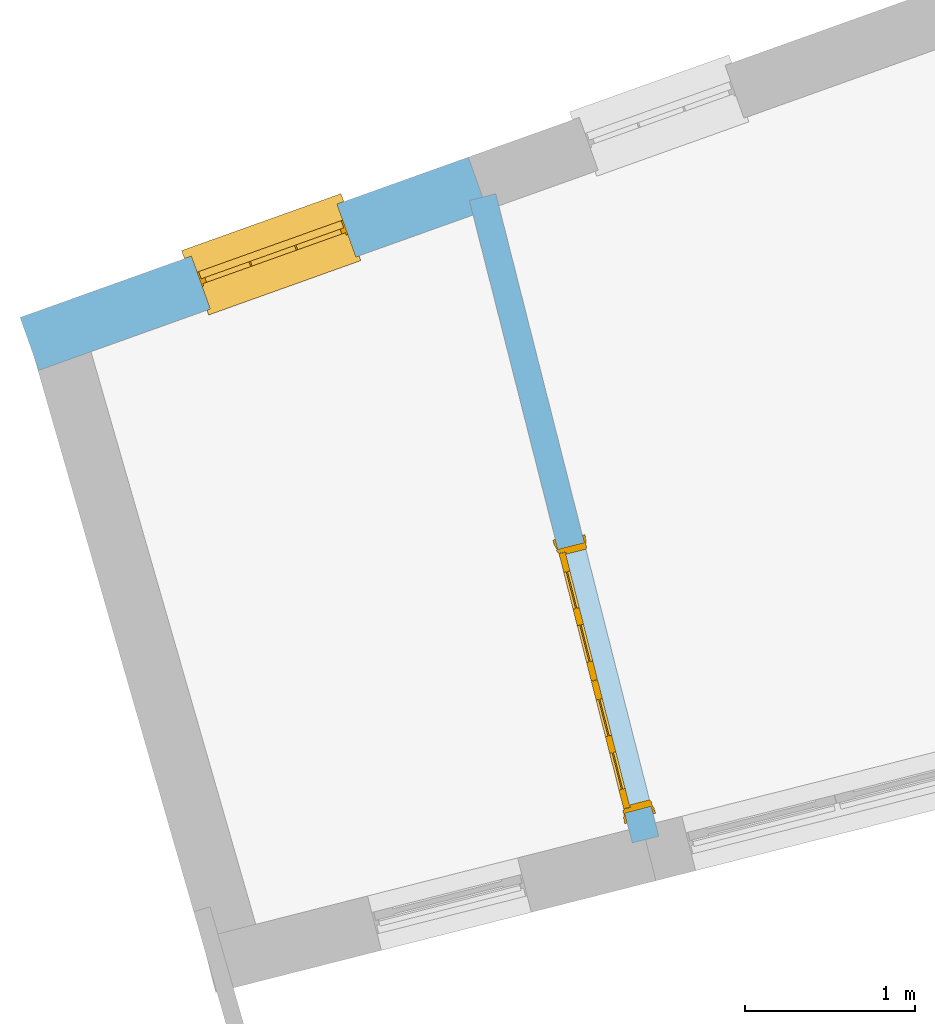
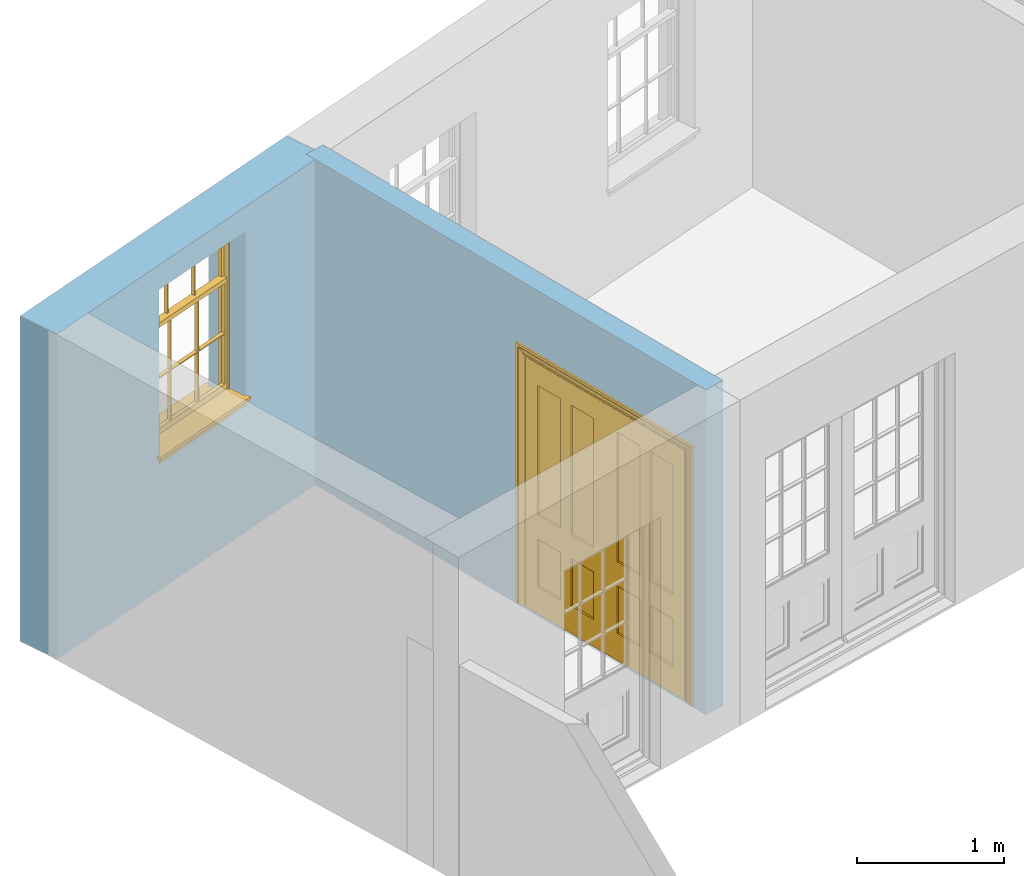
# One storey, part 5 of 15: 1 door, 1 window, 2 openings, plus 2 elements that do not belong to this part.
"""IFC2X3 building model written with IfcOpenShell, lengths in metres."""

from ifc_helpers import new_model, si_unit, frame, origin, place, context, subcontext, project, spatial, polyline, outline, extrude, faceted_brep, material, layer, layer_set, layer_usage, element, fill, save


model = new_model("IFC2X3")

# Units and contexts
model_context = context("Model", 3, world=origin())
body_context = subcontext(model_context, "Body", "Model", "MODEL_VIEW")
ifc_project = project(units=[si_unit("PLANEANGLEUNIT", "RADIAN"), si_unit("MASSUNIT", "GRAM", prefix="KILO"), si_unit("FORCEUNIT", "NEWTON", prefix="KILO"), si_unit("LENGTHUNIT", "METRE")], contexts=[model_context])

# Site, building, storey
site_placement = place(None, origin())
site = spatial("IfcSite", under=ifc_project, at=site_placement, CompositionType="ELEMENT")
building_placement = place(None, origin())
building = spatial("IfcBuilding", under=site, at=building_placement, Name="Building plot-13", CompositionType="ELEMENT")
storey_placement = place(None, frame((0.0, 0.0, 4.0)))
storey = spatial("IfcBuildingStorey", under=building, at=storey_placement, Name="Floor 0", CompositionType="ELEMENT", Elevation=4.0)

# Wall, opening, window
ifc_material_1 = material(Name="Masonry")
ifc_layer_1 = layer(ifc_material_1, 0.33, ventilated=False)
ifc_layer_set_1 = layer_set([ifc_layer_1], Name="My Wall")
ifc_layer_usage_1 = layer_usage(ifc_layer_set_1, "AXIS2", "NEGATIVE", 0.08)
wall_1_placement = place(storey_placement, origin())
wall_1 = element("IfcWallStandardCase", 1, at=wall_1_placement, inside=storey, material=ifc_layer_usage_1, Name="exterior", context=body_context, shape_type="SweptSolid", body=[
    extrude(outline(polyline([(65.8380715197324, 47.5156886625686), (65.7269624100281, 47.8264212899844), (63.0917307447464, 46.8841377369854), (63.2028398544507, 46.5734051095696), (65.8380715197324, 47.5156886625686)])), origin(), (0.0, 0.0, 1.0), 2.7),
])
opening_1_placement = place(storey_placement, frame((0.0, 0.0, 1.05)))
opening_1 = element("IfcOpeningElement", 2, at=opening_1_placement, cuts=wall_1, Name="Opening", ObjectType="Opening", context=body_context, shape_type="SweptSolid", body=[
    extrude(outline(polyline([(64.955482710421, 47.550562191147), (64.0986139499715, 47.2441704037806), (64.2097230596758, 46.9334377763648), (65.0665918201253, 47.2398295637312), (64.955482710421, 47.550562191147)])), origin(), (0.0, 0.0, 1.0), 1.445),
])
window_placement = place(storey_placement, frame((65.0396562783788, 47.315158685529, 1.05), z_axis=(0.0, 0.0, 1.0), x_axis=(-0.856868760449586, -0.306391787366429, 0.0)))
window = element("IfcWindow", 3, at=window_placement, inside=storey, Name="kitchen street window", OverallHeight=1.445, OverallWidth=0.91, context=body_context, shape_type="Brep", held_by="IfcProductRepresentation", body=[
    faceted_brep([(0.876875, -0.105, 0.999097), (0.876875, -0.105, 1.411875), (0.9, -0.105, 1.435), (0.033125, -0.105, 1.411875), (0.033125, -0.105, 0.999097), (0.01, -0.105, 1.435), (0.033125, -0.135, 1.411875), (0.01, -0.135, 1.435), (0.033125, -0.135, 0.999097), (0.876875, -0.135, 1.411875), (0.876875, -0.135, 0.999097), (0.9, -0.135, 1.435), (0.033125, -0.105, 0.960972), (0.01, -0.105, 0.960972), (0.033125, -0.105, 0.548195), (0.876875, -0.105, 0.960972), (0.876875, -0.105, 0.548195), (0.9, -0.105, 0.960972), (0.876875, -0.105, 0.538195), (0.876875, -0.105, 0.125417), (0.9, -0.105, 0.077167), (0.033125, -0.105, 0.125417), (0.033125, -0.105, 0.538195), (0.01, -0.105, 0.077167), (0.9, -0.135, 0.960972), (0.01, -0.135, 0.960972), (-0.0425, -0.25, 0.01), (-0.0425, -0.3, 0.001667), (0.0, -0.25, 0.01), (0.9525, -0.25, 0.01), (0.91, -0.25, 0.01), (0.9525, -0.3, 0.001667), (-0.02, 0.08, 0.077167), (0.0, 0.08, 0.077167), (-0.02, 0.11, 0.077167), (0.0, -0.06, 0.077167), (0.01, -0.06, 0.077167), (0.91, -0.06, 0.077167), (0.91, 0.08, 0.077167), (0.9, -0.06, 0.077167), (0.93, 0.08, 0.077167), (0.93, 0.11, 0.077167), (0.01, -0.105, 0.999097), (0.01, -0.075, 0.999097), (0.9, -0.105, 0.999097), (0.9, -0.075, 0.999097), (0.876875, -0.075, 0.125417), (0.876875, -0.075, 0.538195), (0.9, -0.075, 0.077167), (0.876875, -0.075, 0.548195), (0.876875, -0.075, 0.960972), (0.033125, -0.075, 0.125417), (0.01, -0.075, 0.077167), (0.033125, -0.075, 0.538195), (0.033125, -0.075, 0.960972), (0.033125, -0.075, 0.548195), (-0.02, 0.08, 0.052167), (-0.02, 0.11, 0.052167), (0.93, 0.11, 0.052167), (0.93, 0.08, 0.052167), (0.91, 0.08, 0.052167), (0.0, 0.08, 0.052167), (0.91, -0.15, 0.026667), (0.0, -0.15, 0.026667), (-0.0425, -0.3, -0.123333), (0.9525, -0.3, -0.123333), (-0.0425, -0.25, -0.123333), (0.9525, -0.25, -0.123333), (0.01, -0.06, 1.435), (0.9, -0.06, 1.435), (0.0, -0.06, 1.445), (0.91, -0.06, 1.445), (0.01, -0.15, 0.077167), (0.9, -0.15, 0.077167), (0.592292, -0.105, 0.125417), (0.592292, -0.075, 0.125417), (0.317708, -0.075, 0.125417), (0.317708, -0.105, 0.125417), (0.592292, -0.105, 0.548195), (0.317708, -0.105, 0.548195), (0.317708, -0.105, 0.538195), (0.592292, -0.105, 0.538195), (0.592292, -0.075, 0.548195), (0.317708, -0.075, 0.548195), (0.602292, -0.075, 0.548195), (0.602292, -0.105, 0.548195), (0.317708, -0.075, 0.538195), (0.307708, -0.075, 0.125417), (0.307708, -0.075, 0.538195), (0.602292, -0.075, 0.538195), (0.602292, -0.075, 0.125417), (0.592292, -0.075, 0.538195), (0.307708, -0.075, 0.548195), (0.317708, -0.075, 0.960972), (0.307708, -0.075, 0.960972), (0.602292, -0.075, 0.960972), (0.592292, -0.075, 0.960972), (0.307708, -0.105, 0.538195), (0.307708, -0.105, 0.125417), (0.307708, -0.105, 0.548195), (0.307708, -0.105, 0.960972), (0.592292, -0.105, 0.960972), (0.317708, -0.105, 0.960972), (0.602292, -0.105, 0.960972), (0.602292, -0.105, 0.538195), (0.602292, -0.105, 0.125417), (0.317708, -0.135, 1.411875), (0.307708, -0.135, 1.411875), (0.307708, -0.135, 0.999097), (0.317708, -0.135, 0.999097), (0.602292, -0.135, 1.411875), (0.592292, -0.135, 1.411875), (0.592292, -0.135, 0.999097), (0.602292, -0.135, 0.999097), (0.317708, -0.105, 0.999097), (0.307708, -0.105, 0.999097), (0.307708, -0.105, 1.411875), (0.317708, -0.105, 1.411875), (0.602292, -0.105, 0.999097), (0.592292, -0.105, 0.999097), (0.592292, -0.105, 1.411875), (0.602292, -0.105, 1.411875), (0.91, -0.15, 1.445), (0.9, -0.15, 1.435), (0.01, -0.15, 1.435), (0.0, -0.15, 1.445), (0.91, -0.25, 0.0), (0.0, -0.25, 0.0), (0.91, 0.08, 0.0), (0.0, 0.08, 0.0)], [[[0, 1, 2]], [[3, 4, 5]], [[6, 7, 8]], [[9, 10, 11]], [[12, 13, 14]], [[15, 16, 17]], [[18, 19, 20]], [[21, 22, 23]], [[24, 15, 17]], [[13, 12, 25]], [[26, 27, 28]], [[29, 30, 31]], [[32, 33, 34]], [[35, 36, 33]], [[37, 38, 39]], [[40, 41, 38]], [[42, 4, 43]], [[44, 45, 0]], [[46, 47, 48]], [[49, 50, 45]], [[51, 52, 53]], [[54, 55, 43]], [[38, 33, 36, 39]], [[41, 34, 33, 38]], [[56, 32, 34, 57]], [[57, 34, 41, 58]], [[58, 41, 40, 59]], [[57, 58, 60, 61]], [[52, 48, 39, 36]], [[62, 63, 28, 30]], [[27, 31, 30, 28]], [[27, 64, 65, 31]], [[66, 67, 65, 64]], [[2, 5, 68, 69]], [[68, 70, 71, 69]], [[20, 23, 72, 73]], [[73, 72, 63, 62]], [[74, 75, 76, 77]], [[78, 79, 80, 81]], [[78, 82, 83, 79]], [[16, 49, 84, 85]], [[86, 76, 87, 88]], [[89, 90, 75, 91]], [[92, 88, 53, 55]], [[82, 91, 86, 83]], [[93, 83, 92, 94]], [[95, 84, 82, 96]], [[89, 84, 49, 47]], [[97, 88, 87, 98]], [[22, 53, 88, 97]], [[81, 91, 75, 74]], [[80, 86, 91, 81]], [[77, 76, 86, 80]], [[99, 92, 55, 14]], [[100, 94, 92, 99]], [[101, 96, 82, 78]], [[79, 83, 93, 102]], [[85, 84, 95, 103]], [[104, 89, 47, 18]], [[105, 90, 89, 104]], [[104, 18, 16, 85]], [[80, 97, 98, 77]], [[104, 81, 74, 105]], [[103, 101, 78, 85]], [[99, 14, 22, 97]], [[102, 100, 99, 79]], [[106, 107, 108, 109]], [[110, 111, 112, 113]], [[114, 115, 116, 117]], [[118, 119, 120, 121]], [[107, 116, 115, 108]], [[111, 120, 119, 112]], [[109, 114, 117, 106]], [[113, 118, 121, 110]], [[85, 78, 81, 104]], [[84, 89, 91, 82]], [[83, 86, 88, 92]], [[79, 99, 97, 80]], [[109, 112, 119, 114]], [[102, 93, 96, 101]], [[106, 117, 120, 111]], [[98, 87, 51, 21]], [[6, 3, 116, 107]], [[110, 121, 1, 9]], [[19, 46, 90, 105]], [[26, 66, 64, 27]], [[29, 31, 65, 67]], [[25, 24, 112, 109]], [[11, 7, 106, 111]], [[75, 48, 52, 76]], [[43, 45, 96, 93]], [[45, 43, 114, 119]], [[5, 2, 120, 117]], [[24, 25, 102, 101]], [[42, 5, 4]], [[2, 44, 0]], [[49, 45, 48, 47]], [[52, 43, 55, 53]], [[14, 13, 23, 22]], [[20, 17, 16, 18]], [[24, 11, 10]], [[25, 8, 7]], [[8, 4, 3, 6]], [[9, 1, 0, 10]], [[15, 50, 49, 16]], [[18, 47, 46, 19]], [[21, 51, 53, 22]], [[14, 55, 54, 12]], [[44, 2, 69, 45]], [[68, 5, 42, 43]], [[36, 35, 70, 68]], [[39, 69, 71, 37]], [[62, 122, 123, 73]], [[63, 72, 124, 125]], [[8, 108, 115, 4]], [[113, 10, 0, 118]], [[94, 100, 12, 54]], [[17, 20, 73, 24]], [[72, 23, 13, 25]], [[52, 36, 68, 43]], [[69, 39, 48, 45]], [[11, 24, 73, 123]], [[7, 124, 72, 25]], [[23, 77, 98]], [[98, 21, 23]], [[105, 74, 20]], [[20, 19, 105]], [[20, 74, 77, 23]], [[113, 112, 24]], [[24, 10, 113]], [[25, 109, 108]], [[108, 8, 25]], [[110, 9, 11]], [[11, 111, 110]], [[7, 6, 107]], [[107, 106, 7]], [[5, 117, 116]], [[116, 3, 5]], [[121, 120, 2]], [[2, 1, 121]], [[11, 123, 124, 7]], [[122, 125, 124, 123]], [[43, 93, 94]], [[94, 54, 43]], [[96, 45, 95]], [[50, 95, 45]], [[15, 103, 95, 50]], [[48, 75, 90]], [[90, 46, 48]], [[87, 76, 52]], [[52, 51, 87]], [[103, 15, 24]], [[24, 101, 103]], [[100, 102, 25]], [[25, 12, 100]], [[115, 114, 43]], [[43, 4, 115]], [[118, 0, 45]], [[45, 119, 118]], [[71, 70, 125, 122]], [[70, 35, 63, 125]], [[122, 62, 37, 71]], [[126, 67, 66, 127]], [[60, 58, 59]], [[38, 60, 59, 40]], [[61, 56, 57]], [[32, 56, 61, 33]], [[61, 60, 128, 129]], [[62, 60, 38, 37]], [[126, 128, 60, 62]], [[33, 61, 63, 35]], [[61, 129, 127, 63]], [[128, 126, 127, 129]], [[28, 127, 66, 26]], [[63, 127, 28]], [[29, 67, 126, 30]], [[30, 126, 62]]]),
])
fill(opening_1, window)

# Wall, opening, door
ifc_material_2 = material(Name="Masonry")
ifc_layer_2 = layer(ifc_material_2, 0.16, ventilated=False)
ifc_layer_set_2 = layer_set([ifc_layer_2], Name="My Wall")
ifc_layer_usage_2 = layer_usage(ifc_layer_set_2, "AXIS2", "NEGATIVE", 0.08)
wall_2_placement = place(storey_placement, origin())
wall_2 = element("IfcWallStandardCase", 4, at=wall_2_placement, inside=storey, material=ifc_layer_usage_2, Name="interior", context=body_context, shape_type="SweptSolid", body=[
    extrude(outline(polyline([(66.6912837774375, 43.7953637228616), (66.8463733153189, 43.8346986340692), (65.8886807469266, 47.6106852399702), (65.7335912090452, 47.5713503287626), (66.6912837774375, 43.7953637228616)])), origin(), (0.0, 0.0, 1.0), 2.7),
])
opening_2_placement = place(storey_placement, frame((0.0, 0.0, 0.0199999999999996)))
opening_2 = element("IfcOpeningElement", 5, at=opening_2_placement, cuts=wall_2, Name="Opening", ObjectType="Opening", context=body_context, shape_type="SweptSolid", body=[
    extrude(outline(polyline([(66.8021215402103, 44.0091743641859), (66.4087724281336, 45.5600697430005), (66.2536828902521, 45.5207348317928), (66.6470320023288, 43.9698394529782), (66.8021215402103, 44.0091743641859)])), origin(), (0.0, 0.0, 1.0), 2.1),
])
door_placement = place(storey_placement, frame((66.7245767712696, 43.989506908582, 0.0199999999999996), z_axis=(0.0, 0.0, 1.0), x_axis=(-0.393349112076706, 1.55089537881459, 0.0)))
door = element("IfcDoor", 6, at=door_placement, inside=storey, Name="kitchen living inside door", OverallHeight=2.1, OverallWidth=1.6, context=body_context, shape_type="Brep", held_by="IfcProductRepresentation", body=[
    faceted_brep([(0.14, 0.057, 1.895), (0.14, 0.057, 0.82), (0.363, 0.057, 0.82), (0.363, 0.057, 1.895), (0.14, 0.042, 1.895), (0.14, 0.042, 0.82), (0.363, 0.042, 0.82), (0.363, 0.042, 1.895), (0.027, 0.042, 1.895), (0.027, 0.042, 0.82), (0.363, 0.042, 0.62), (0.14, 0.042, 0.62), (0.463, 0.042, 0.82), (0.463, 0.042, 1.895), (0.363, 0.042, 2.073), (0.14, 0.042, 2.073), (0.027, 0.042, 2.073), (0.027, 0.08, 1.895), (0.027, 0.08, 0.82), (0.027, 0.042, 0.62), (0.463, 0.042, 0.62), (0.14, 0.057, 0.62), (0.363, 0.057, 0.62), (0.463, 0.057, 0.82), (0.463, 0.057, 1.895), (0.463, 0.042, 2.073), (0.14, 0.08, 2.073), (0.363, 0.08, 2.073), (0.027, 0.08, 2.073), (0.14, 0.08, 1.895), (0.14, 0.08, 0.82), (0.027, 0.08, 0.62), (0.027, 0.042, 0.225), (0.14, 0.042, 0.225), (0.363, 0.042, 0.225), (0.463, 0.042, 0.225), (0.686, 0.042, 0.62), (0.686, 0.042, 0.82), (0.14, 0.057, 0.225), (0.363, 0.057, 0.225), (0.686, 0.057, 0.82), (0.686, 0.057, 1.895), (0.686, 0.042, 1.895), (0.686, 0.042, 2.073), (0.463, 0.08, 2.073), (0.363, 0.08, 1.895), (0.14, 0.065, 1.895), (0.14, 0.065, 0.82), (0.14, 0.08, 0.62), (0.027, 0.08, 0.225), (0.027, 0.042, 0.0), (0.14, 0.042, 0.0), (0.363, 0.042, 0.0), (0.463, 0.042, 0.0), (0.463, 0.057, 0.225), (0.463, 0.057, 0.62), (0.686, 0.057, 0.62), (0.799, 0.042, 0.62), (0.799, 0.042, 0.82), (0.799, 0.042, 1.895), (0.799, 0.042, 2.073), (0.686, 0.08, 2.073), (0.463, 0.08, 1.895), (0.363, 0.065, 1.895), (0.363, 0.065, 0.82), (0.363, 0.08, 0.82), (0.363, 0.08, 0.62), (0.14, 0.08, 0.225), (0.027, 0.08, 0.0), (0.14, 0.08, 0.0), (0.363, 0.08, 0.0), (0.463, 0.08, 0.0), (0.686, 0.042, 0.0), (0.686, 0.042, 0.225), (0.686, 0.057, 0.225), (0.799, 0.042, 0.225), (0.799, 0.08, 0.62), (0.799, 0.08, 0.82), (0.799, 0.08, 1.895), (0.799, 0.08, 2.073), (0.686, 0.08, 1.895), (0.463, 0.08, 0.82), (0.463, 0.08, 0.62), (0.363, 0.065, 0.62), (0.14, 0.065, 0.62), (0.14, 0.065, 0.225), (0.363, 0.08, 0.225), (0.463, 0.08, 0.225), (0.686, 0.08, 0.0), (0.799, 0.042, 0.0), (0.799, 0.08, 0.225), (0.686, 0.08, 0.62), (0.686, 0.08, 0.82), (0.686, 0.065, 1.895), (0.463, 0.065, 1.895), (0.463, 0.065, 0.82), (0.363, 0.065, 0.225), (0.686, 0.08, 0.225), (0.799, 0.08, 0.0), (0.686, 0.065, 0.82), (0.463, 0.065, 0.62), (0.463, 0.065, 0.225), (0.686, 0.065, 0.62), (0.686, 0.065, 0.225), (1.46, 0.08, 1.895), (1.237, 0.08, 1.895), (1.237, 0.08, 2.073), (1.46, 0.08, 2.073), (1.46, 0.065, 1.895), (1.237, 0.065, 1.895), (1.137, 0.08, 1.895), (1.137, 0.08, 2.073), (1.237, 0.042, 2.073), (1.46, 0.042, 2.073), (1.573, 0.08, 1.895), (1.573, 0.08, 2.073), (1.46, 0.08, 0.82), (1.46, 0.065, 0.82), (1.237, 0.065, 0.82), (1.237, 0.08, 0.82), (1.137, 0.08, 0.82), (0.914, 0.08, 2.073), (0.914, 0.08, 1.895), (1.137, 0.042, 2.073), (1.237, 0.042, 1.895), (1.46, 0.042, 1.895), (1.573, 0.042, 2.073), (1.573, 0.08, 0.82), (1.573, 0.042, 1.895), (1.237, 0.08, 0.62), (1.137, 0.08, 0.62), (1.137, 0.065, 0.82), (1.137, 0.065, 1.895), (0.914, 0.042, 2.073), (0.914, 0.065, 1.895), (0.801, 0.08, 2.073), (0.801, 0.08, 1.895), (1.137, 0.042, 1.895), (1.237, 0.057, 1.895), (1.46, 0.057, 1.895), (1.573, 0.042, 0.82), (1.573, 0.08, 0.62), (1.46, 0.08, 0.62), (1.237, 0.08, 0.225), (1.137, 0.08, 0.225), (0.914, 0.08, 0.82), (0.914, 0.08, 0.62), (0.914, 0.065, 0.82), (0.801, 0.042, 2.073), (0.914, 0.042, 1.895), (0.801, 0.08, 0.82), (0.801, 0.042, 1.895), (1.137, 0.042, 0.82), (1.237, 0.042, 0.82), (1.237, 0.057, 0.82), (1.46, 0.057, 0.82), (1.46, 0.042, 0.82), (1.573, 0.042, 0.62), (1.573, 0.08, 0.225), (1.46, 0.08, 0.225), (1.46, 0.065, 0.62), (1.237, 0.065, 0.62), (1.237, 0.08, 0.0), (1.137, 0.08, 0.0), (1.137, 0.065, 0.225), (1.137, 0.065, 0.62), (1.237, 0.065, 0.225), (0.914, 0.065, 0.62), (0.801, 0.08, 0.62), (0.914, 0.057, 1.895), (1.137, 0.057, 1.895), (0.801, 0.042, 0.82), (1.137, 0.042, 0.62), (1.237, 0.042, 0.62), (1.137, 0.057, 0.82), (1.46, 0.042, 0.62), (1.573, 0.042, 0.225), (1.573, 0.08, 0.0), (1.46, 0.08, 0.0), (1.46, 0.065, 0.225), (1.237, 0.042, 0.0), (1.137, 0.042, 0.0), (0.914, 0.08, 0.225), (0.914, 0.08, 0.0), (0.914, 0.065, 0.225), (0.801, 0.08, 0.225), (0.801, 0.042, 0.62), (0.914, 0.042, 0.82), (0.914, 0.057, 0.82), (1.137, 0.042, 0.225), (1.237, 0.042, 0.225), (0.914, 0.042, 0.62), (1.46, 0.042, 0.225), (1.573, 0.042, 0.0), (1.46, 0.042, 0.0), (0.914, 0.042, 0.0), (0.801, 0.08, 0.0), (0.801, 0.042, 0.225), (1.237, 0.057, 0.225), (1.237, 0.057, 0.62), (1.137, 0.057, 0.62), (1.137, 0.057, 0.225), (1.46, 0.057, 0.62), (0.914, 0.057, 0.62), (1.46, 0.057, 0.225), (0.914, 0.042, 0.225), (0.801, 0.042, 0.0), (0.914, 0.057, 0.225), (0.02, 0.085, 0.0), (0.005, 0.09, 0.0), (0.005, 0.09, 2.095), (0.02, 0.085, 2.08), (0.02, 0.08, 0.0), (0.0, 0.085, 0.0), (0.0, 0.085, 2.1), (1.595, 0.09, 2.095), (1.58, 0.085, 2.08), (0.02, 0.08, 2.08), (0.0, 0.08, 0.0), (-0.032, 0.095, 0.0), (-0.032, 0.095, 2.132), (1.6, 0.085, 2.1), (1.595, 0.09, 0.0), (1.58, 0.085, 0.0), (1.58, 0.08, 2.08), (0.025, 0.08, 0.0), (0.025, 0.08, 2.075), (-0.04, 0.09, 0.0), (0.025, 0.04, 0.0), (0.0, -0.08, 0.0), (-0.04, 0.09, 2.14), (1.632, 0.095, 2.132), (1.6, 0.085, 0.0), (1.58, 0.08, 0.0), (1.575, 0.08, 2.075), (0.025, 0.04, 2.075), (-0.06, 0.08, 0.0), (0.035, -0.08, 0.0), (0.0, -0.08, 2.1), (0.0, 0.08, 2.1), (-0.04, 0.095, 0.0), (-0.04, 0.095, 2.14), (1.64, 0.09, 2.14), (1.632, 0.095, 0.0), (1.6, 0.08, 0.0), (1.575, 0.08, 0.0), (1.575, 0.04, 2.075), (0.04, 0.04, 0.0), (0.04, 0.04, 2.06), (-0.06, 0.095, 0.0), (-0.06, 0.08, 2.16), (0.015, -0.085, 0.0), (0.04, -0.08, 0.0), (-0.045, -0.08, 2.145), (-0.045, -0.08, 0.0), (1.6, -0.08, 2.1), (1.6, 0.08, 2.1), (-0.06, 0.095, 2.16), (1.64, 0.095, 2.14), (1.64, 0.09, 0.0), (1.6, -0.08, 0.0), (1.575, 0.04, 0.0), (1.56, 0.04, 2.06), (0.04, -0.08, 2.06), (1.66, 0.08, 2.16), (-0.017, -0.095, 0.0), (-0.025, -0.09, 0.0), (0.02, -0.09, 0.0), (0.035, -0.085, 0.0), (0.035, -0.08, 2.065), (1.645, -0.08, 2.145), (-0.045, -0.095, 2.145), (-0.045, -0.095, 0.0), (1.66, 0.095, 2.16), (1.64, 0.095, 0.0), (1.66, 0.08, 0.0), (1.565, -0.08, 0.0), (1.56, 0.04, 0.0), (1.56, -0.08, 2.06), (-0.017, -0.095, 2.117), (-0.025, -0.09, 2.125), (0.015, -0.085, 2.085), (0.02, -0.09, 2.08), (0.035, -0.085, 2.065), (1.565, -0.08, 2.065), (1.645, -0.08, 0.0), (1.645, -0.095, 2.145), (-0.025, -0.095, 0.0), (1.66, 0.095, 0.0), (1.585, -0.085, 0.0), (1.56, -0.08, 0.0), (1.617, -0.095, 2.117), (1.625, -0.09, 2.125), (-0.025, -0.095, 2.125), (1.585, -0.085, 2.085), (1.58, -0.09, 2.08), (1.565, -0.085, 2.065), (1.625, -0.09, 0.0), (1.645, -0.095, 0.0), (1.625, -0.095, 2.125), (1.617, -0.095, 0.0), (1.565, -0.085, 0.0), (1.58, -0.09, 0.0), (1.625, -0.095, 0.0)], [[[0, 1, 2, 3]], [[1, 0, 4, 5]], [[2, 1, 5, 6]], [[6, 7, 3, 2]], [[7, 4, 0, 3]], [[4, 8, 9, 5]], [[10, 6, 5, 11]], [[6, 12, 13, 7]], [[14, 15, 4, 7]], [[15, 16, 8, 4]], [[9, 8, 17, 18]], [[5, 9, 19, 11]], [[10, 20, 12, 6]], [[10, 11, 21, 22]], [[13, 12, 23, 24]], [[7, 13, 25, 14]], [[26, 15, 14, 27]], [[28, 16, 15, 26]], [[8, 16, 28, 17]], [[17, 29, 30, 18]], [[18, 31, 19, 9]], [[11, 19, 32, 33]], [[34, 35, 20, 10]], [[20, 36, 37, 12]], [[11, 33, 38, 21]], [[39, 22, 21, 38]], [[34, 10, 22, 39]], [[12, 37, 40, 23]], [[24, 23, 40, 41]], [[42, 13, 24, 41]], [[13, 42, 43, 25]], [[14, 25, 44, 27]], [[26, 27, 45, 29]], [[28, 26, 29, 17]], [[30, 29, 46, 47]], [[18, 30, 48, 31]], [[31, 49, 32, 19]], [[33, 32, 50, 51]], [[52, 53, 35, 34]], [[20, 35, 54, 55]], [[36, 20, 55, 56]], [[36, 57, 58, 37]], [[33, 34, 39, 38]], [[37, 42, 41, 40]], [[42, 59, 60, 43]], [[44, 25, 43, 61]], [[62, 45, 27, 44]], [[29, 45, 63, 46]], [[46, 63, 64, 47]], [[65, 30, 47, 64]], [[30, 65, 66, 48]], [[31, 48, 67, 49]], [[68, 50, 32, 49]], [[68, 69, 51, 50]], [[34, 33, 51, 52]], [[53, 52, 70, 71]], [[53, 72, 73, 35]], [[35, 73, 74, 54]], [[55, 54, 74, 56]], [[73, 36, 56, 74]], [[73, 75, 57, 36]], [[57, 76, 77, 58]], [[37, 58, 59, 42]], [[78, 79, 60, 59]], [[60, 79, 61, 43]], [[80, 62, 44, 61]], [[81, 65, 45, 62]], [[45, 65, 64, 63]], [[82, 66, 65, 81]], [[48, 66, 83, 84]], [[67, 48, 84, 85]], [[49, 67, 69, 68]], [[52, 51, 69, 70]], [[71, 70, 86, 87]], [[72, 53, 71, 88]], [[72, 89, 75, 73]], [[75, 90, 76, 57]], [[76, 91, 92, 77]], [[78, 59, 58, 77]], [[78, 80, 61, 79]], [[62, 80, 93, 94]], [[81, 62, 94, 95]], [[87, 86, 66, 82]], [[91, 82, 81, 92]], [[66, 86, 96, 83]], [[84, 83, 96, 85]], [[86, 67, 85, 96]], [[67, 86, 70, 69]], [[88, 71, 87, 97]], [[89, 72, 88, 98]], [[89, 98, 90, 75]], [[90, 97, 91, 76]], [[80, 78, 77, 92]], [[80, 92, 99, 93]], [[99, 95, 94, 93]], [[92, 81, 95, 99]], [[87, 82, 100, 101]], [[82, 91, 102, 100]], [[97, 87, 101, 103]], [[98, 88, 97, 90]], [[91, 97, 103, 102]], [[103, 101, 100, 102]], [[104, 105, 106, 107]], [[105, 104, 108, 109]], [[105, 110, 111, 106]], [[106, 112, 113, 107]], [[114, 104, 107, 115]], [[104, 116, 117, 108]], [[117, 118, 109, 108]], [[119, 105, 109, 118]], [[119, 120, 110, 105]], [[121, 111, 110, 122]], [[123, 112, 106, 111]], [[124, 125, 113, 112]], [[126, 115, 107, 113]], [[104, 114, 127, 116]], [[114, 115, 126, 128]], [[116, 119, 118, 117]], [[129, 130, 120, 119]], [[110, 120, 131, 132]], [[121, 133, 123, 111]], [[122, 110, 132, 134]], [[135, 121, 122, 136]], [[137, 124, 112, 123]], [[125, 124, 138, 139]], [[125, 128, 126, 113]], [[114, 128, 140, 127]], [[141, 142, 116, 127]], [[142, 129, 119, 116]], [[143, 144, 130, 129]], [[145, 120, 130, 146]], [[120, 145, 147, 131]], [[134, 132, 131, 147]], [[135, 148, 133, 121]], [[123, 133, 149, 137]], [[145, 122, 134, 147]], [[136, 122, 145, 150]], [[151, 148, 135, 136]], [[152, 153, 124, 137]], [[124, 153, 154, 138]], [[138, 154, 155, 139]], [[156, 125, 139, 155]], [[156, 140, 128, 125]], [[157, 141, 127, 140]], [[158, 159, 142, 141]], [[129, 142, 160, 161]], [[162, 163, 144, 143]], [[130, 144, 164, 165]], [[143, 129, 161, 166]], [[146, 130, 165, 167]], [[150, 145, 146, 168]], [[133, 148, 151, 149]], [[137, 149, 169, 170]], [[171, 151, 136, 150]], [[172, 173, 153, 152]], [[152, 137, 170, 174]], [[153, 156, 155, 154]], [[175, 157, 140, 156]], [[176, 158, 141, 157]], [[177, 178, 159, 158]], [[142, 159, 179, 160]], [[179, 166, 161, 160]], [[180, 181, 163, 162]], [[182, 144, 163, 183]], [[178, 162, 143, 159]], [[144, 182, 184, 164]], [[167, 165, 164, 184]], [[159, 143, 166, 179]], [[182, 146, 167, 184]], [[168, 146, 182, 185]], [[150, 168, 186, 171]], [[149, 151, 171, 187]], [[149, 187, 188, 169]], [[169, 188, 174, 170]], [[189, 190, 173, 172]], [[173, 175, 156, 153]], [[172, 152, 187, 191]], [[187, 152, 174, 188]], [[192, 176, 157, 175]], [[193, 177, 158, 176]], [[193, 194, 178, 177]], [[181, 180, 190, 189]], [[181, 195, 183, 163]], [[194, 180, 162, 178]], [[185, 182, 183, 196]], [[168, 185, 197, 186]], [[187, 171, 186, 191]], [[173, 190, 198, 199]], [[189, 172, 200, 201]], [[175, 173, 199, 202]], [[172, 191, 203, 200]], [[194, 193, 176, 192]], [[192, 175, 202, 204]], [[180, 194, 192, 190]], [[189, 205, 195, 181]], [[196, 183, 195, 206]], [[196, 206, 197, 185]], [[191, 186, 197, 205]], [[190, 192, 204, 198]], [[199, 198, 204, 202]], [[201, 200, 203, 207]], [[205, 189, 201, 207]], [[191, 205, 207, 203]], [[205, 197, 206, 195]], [[208, 209, 210, 211]], [[208, 212, 213, 209]], [[209, 213, 214, 210]], [[211, 210, 215, 216]], [[211, 217, 212, 208]], [[218, 213, 212]], [[213, 219, 220, 214]], [[210, 214, 221, 215]], [[216, 215, 222, 223]], [[217, 211, 216, 224]], [[225, 212, 217, 226]], [[219, 213, 218, 227]], [[218, 212, 228, 229]], [[219, 227, 230, 220]], [[214, 220, 231, 221]], [[215, 221, 232, 222]], [[222, 232, 233, 223]], [[224, 216, 223, 233]], [[226, 217, 224, 234]], [[225, 228, 212]], [[235, 228, 225, 226]], [[236, 227, 218]], [[237, 229, 228]], [[229, 238, 239, 218]], [[227, 240, 241, 230]], [[220, 230, 242, 231]], [[221, 231, 243, 232]], [[244, 233, 232]], [[234, 224, 233, 245]], [[246, 235, 226, 234]], [[247, 228, 235, 248]], [[240, 227, 236, 249]], [[239, 250, 236, 218]], [[251, 229, 237]], [[252, 237, 228, 247]], [[253, 238, 229, 254]], [[238, 255, 256, 239]], [[241, 240, 257]], [[230, 241, 258, 242]], [[231, 242, 259, 243]], [[259, 244, 232, 243]], [[260, 261, 233, 244]], [[245, 233, 261]], [[261, 246, 234, 245]], [[248, 235, 246, 262]], [[248, 263, 252, 247]], [[250, 257, 249, 236]], [[240, 249, 257]], [[256, 264, 250, 239]], [[265, 266, 229, 251]], [[267, 251, 237, 268]], [[263, 269, 237, 252]], [[270, 255, 238, 253]], [[229, 266, 254]], [[271, 253, 254, 272]], [[256, 255, 260, 244]], [[273, 241, 257]], [[273, 258, 241]], [[242, 258, 274, 259]], [[275, 244, 259]], [[260, 276, 261]], [[261, 277, 262, 246]], [[262, 278, 263, 248]], [[264, 273, 257, 250]], [[244, 275, 264, 256]], [[266, 265, 279, 280]], [[265, 251, 281, 279]], [[251, 267, 282, 281]], [[269, 283, 268, 237]], [[267, 268, 283, 282]], [[278, 284, 269, 263]], [[285, 260, 255, 270]], [[286, 270, 253, 271]], [[272, 254, 266, 287]], [[271, 272, 287]], [[273, 274, 258]], [[288, 275, 259, 274]], [[276, 260, 289]], [[277, 261, 276, 290]], [[278, 262, 277, 290]], [[275, 288, 273, 264]], [[280, 279, 291, 292]], [[287, 266, 280, 293]], [[279, 281, 294, 291]], [[281, 282, 295, 294]], [[284, 296, 283, 269]], [[282, 283, 296, 295]], [[290, 276, 284, 278]], [[285, 297, 260]], [[298, 285, 270, 286]], [[299, 286, 271]], [[271, 287, 293]], [[273, 288, 274]], [[300, 289, 260, 297]], [[301, 276, 289, 302]], [[292, 291, 300, 297]], [[293, 280, 292, 299]], [[291, 294, 289, 300]], [[294, 295, 302, 289]], [[296, 284, 276, 301]], [[295, 296, 301, 302]], [[303, 297, 285, 298]], [[299, 298, 286]], [[271, 293, 299]], [[299, 292, 297, 303]], [[299, 303, 298]]]),
])
fill(opening_2, door)

save(model, "model.ifc")
